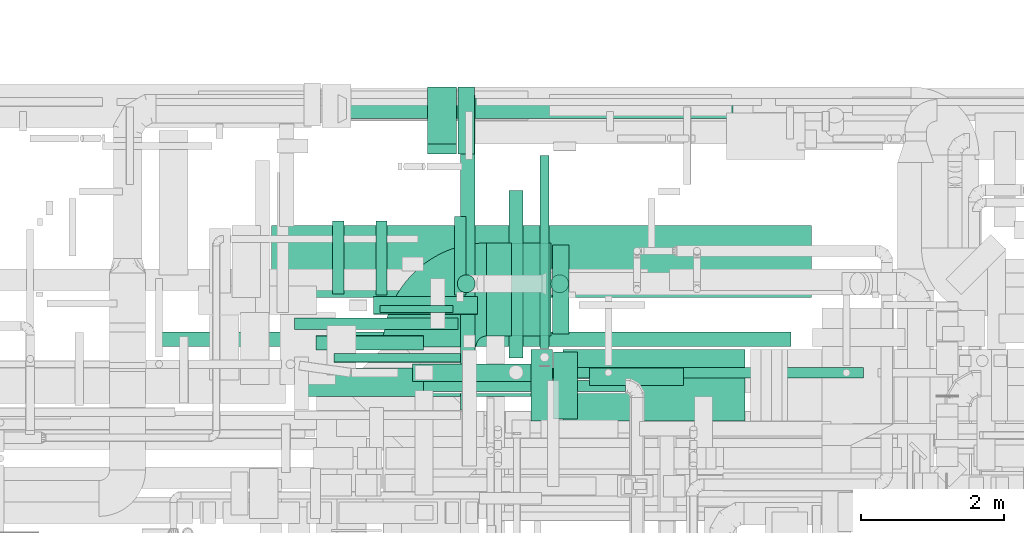
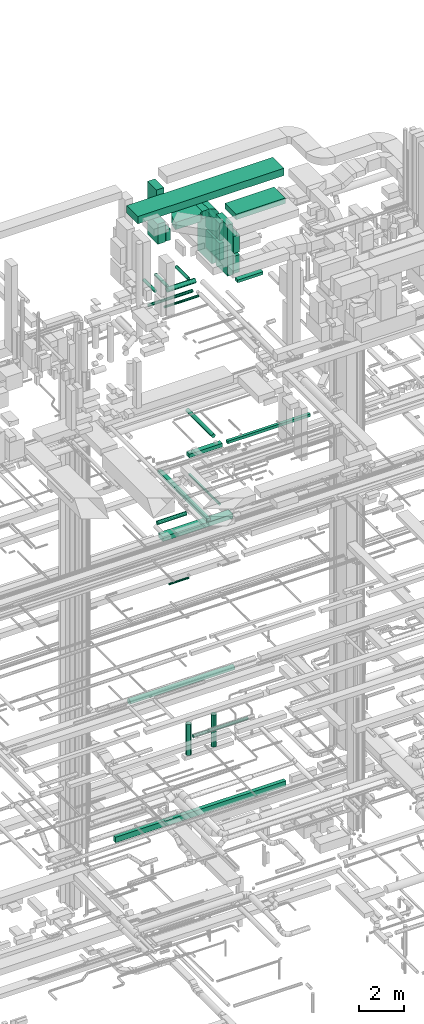
# One storey, part 72 of 337: 32 flow segments, 2 flow fittings.
"""IFC2X3 building model written with IfcOpenShell, lengths in millimetres."""

from ifc_helpers import new_model, entity, si_unit, converted_unit, derived_unit, direction, frame, frame_2d, origin, origin_2d_with_axis, place, context, subcontext, project, spatial, polyline, circle_curve, parameter, trimmed, segment, composite_curve, rectangle, circle, outline, extrude, source, transform, mapped, material, type_object, type_shapes, element, save


model = new_model("IFC2X3")

# Units and contexts
model_context = context("Model", 3, precision=0.01, world=origin(), true_north=direction((6.12303176911189e-17, 1.0)))
body_context = subcontext(model_context, "Body", "Model", "MODEL_VIEW")
ifc_project = project(units=[si_unit("LENGTHUNIT", "METRE", prefix="MILLI"), si_unit("AREAUNIT", "SQUARE_METRE"), si_unit("VOLUMEUNIT", "CUBIC_METRE"), converted_unit("PLANEANGLEUNIT", "DEGREE", entity("IfcRatioMeasure", 0.0174532925199433), si_unit("PLANEANGLEUNIT", "RADIAN"), dimensions=[0, 0, 0, 0, 0, 0, 0]), si_unit("MASSUNIT", "GRAM", prefix="KILO"), derived_unit("MASSDENSITYUNIT", [(si_unit("MASSUNIT", "GRAM", prefix="KILO"), 1), (si_unit("LENGTHUNIT", "METRE"), -3)]), derived_unit("MOMENTOFINERTIAUNIT", [(si_unit("LENGTHUNIT", "METRE"), 4)]), si_unit("TIMEUNIT", "SECOND"), si_unit("FREQUENCYUNIT", "HERTZ"), si_unit("THERMODYNAMICTEMPERATUREUNIT", "DEGREE_CELSIUS"), derived_unit("THERMALTRANSMITTANCEUNIT", [(si_unit("MASSUNIT", "GRAM", prefix="KILO"), 1), (si_unit("THERMODYNAMICTEMPERATUREUNIT", "KELVIN"), -1), (si_unit("TIMEUNIT", "SECOND"), -3)]), derived_unit("VOLUMETRICFLOWRATEUNIT", [(si_unit("LENGTHUNIT", "METRE"), 3), (si_unit("TIMEUNIT", "SECOND"), -1)]), derived_unit("MASSFLOWRATEUNIT", [(si_unit("MASSUNIT", "GRAM", prefix="KILO"), 1), (si_unit("TIMEUNIT", "SECOND"), -1)]), derived_unit("ROTATIONALFREQUENCYUNIT", [(si_unit("TIMEUNIT", "SECOND"), -1)]), si_unit("ELECTRICCURRENTUNIT", "AMPERE"), si_unit("ELECTRICVOLTAGEUNIT", "VOLT"), si_unit("POWERUNIT", "WATT"), si_unit("FORCEUNIT", "NEWTON", prefix="KILO"), si_unit("ILLUMINANCEUNIT", "LUX"), si_unit("LUMINOUSFLUXUNIT", "LUMEN"), si_unit("LUMINOUSINTENSITYUNIT", "CANDELA"), derived_unit("USERDEFINED", [(si_unit("MASSUNIT", "GRAM", prefix="KILO"), -1), (si_unit("LENGTHUNIT", "METRE"), -2), (si_unit("TIMEUNIT", "SECOND"), 3), (si_unit("LUMINOUSFLUXUNIT", "LUMEN"), 1)]), derived_unit("LINEARVELOCITYUNIT", [(si_unit("LENGTHUNIT", "METRE"), 1), (si_unit("TIMEUNIT", "SECOND"), -1)]), si_unit("PRESSUREUNIT", "PASCAL"), derived_unit("USERDEFINED", [(si_unit("LENGTHUNIT", "METRE"), -2), (si_unit("MASSUNIT", "GRAM", prefix="KILO"), 1), (si_unit("TIMEUNIT", "SECOND"), -2)]), derived_unit("LINEARFORCEUNIT", [(si_unit("MASSUNIT", "GRAM", prefix="KILO"), 1), (si_unit("LENGTHUNIT", "METRE"), 1), (si_unit("TIMEUNIT", "SECOND"), -2), (si_unit("LENGTHUNIT", "METRE"), -1)]), derived_unit("PLANARFORCEUNIT", [(si_unit("MASSUNIT", "GRAM", prefix="KILO"), 1), (si_unit("LENGTHUNIT", "METRE"), 1), (si_unit("TIMEUNIT", "SECOND"), -2), (si_unit("LENGTHUNIT", "METRE"), -2)])], contexts=[model_context])

# Site, building, storey
site_placement = place(None, origin())
site = spatial("IfcSite", under=ifc_project, at=site_placement, CompositionType="ELEMENT")
building_placement = place(site_placement, origin())
building = spatial("IfcBuilding", under=site, at=building_placement, CompositionType="ELEMENT")
storey_placement = place(building_placement, origin())
storey = spatial("IfcBuildingStorey", under=building, at=storey_placement, CompositionType="ELEMENT", Elevation=0.0)

# Flow segments
duct_segment_type_1 = type_object("IfcDuctSegmentType", PredefinedType="NOTDEFINED")
flow_segment_1_placement = place(storey_placement, frame((35783.68, 16501.37, -1325.0)))
element("IfcFlowSegment", 1, at=flow_segment_1_placement, inside=storey, type_object=duct_segment_type_1, context=body_context, shape_type="SweptSolid", body=[
    extrude(rectangle(XDim=8799.85393288675, YDim=200.0, at=origin_2d_with_axis()), frame((4399.93, 100.0, 0.0)), (0.0, 0.0, 1.0), 300.0),
])
flow_segment_2_placement = place(storey_placement, frame((41318.08, 16056.51, 18775.0)))
element("IfcFlowSegment", 2, at=flow_segment_2_placement, inside=storey, type_object=duct_segment_type_1, context=body_context, shape_type="SweptSolid", body=[
    extrude(rectangle(XDim=4279.99863965775, YDim=150.000000000001, at=origin_2d_with_axis()), frame((2140.0, 75.0, 0.0)), (0.0, 0.0, 1.0), 149.999999999999),
])
flow_segment_3_placement = place(storey_placement, frame((39298.08, 16006.51, 18750.0)))
element("IfcFlowSegment", 3, at=flow_segment_3_placement, inside=storey, type_object=duct_segment_type_1, context=body_context, shape_type="SweptSolid", body=[
    extrude(rectangle(XDim=1720.0, YDim=249.999999999999, at=origin_2d_with_axis()), frame((860.0, 125.0, 0.0), z_axis=(0.0, 0.0, 1.0), x_axis=(-1.0, 0.0, 0.0)), (0.0, 0.0, 1.0), 199.999999999998),
])
flow_segment_4_placement = place(storey_placement, frame((37828.68, 15800.0, 14825.0)))
element("IfcFlowSegment", 4, at=flow_segment_4_placement, inside=storey, type_object=duct_segment_type_1, context=body_context, shape_type="SweptSolid", body=[
    extrude(rectangle(XDim=3619.99999999995, YDim=400.0, at=origin_2d_with_axis()), frame((1810.0, 200.0, 0.0), z_axis=(0.0, 0.0, 1.0), x_axis=(-1.0, 0.0, 0.0)), (0.0, 0.0, 1.0), 249.999999999999),
])
flow_segment_5_placement = place(storey_placement, frame((39972.01, 15610.0, 15275.0)))
element("IfcFlowSegment", 5, at=flow_segment_5_placement, inside=storey, type_object=duct_segment_type_1, context=body_context, shape_type="SweptSolid", body=[
    extrude(rectangle(XDim=4399.99999999994, YDim=199.999999999998, at=origin_2d_with_axis()), frame((100.0, 2200.0, 0.0), z_axis=(0.0, 0.0, 1.0), x_axis=(0.0, 1.0, 0.0)), (0.0, 0.0, 1.0), 150.000000000001),
])
flow_segment_6_placement = place(storey_placement, frame((41771.44, 15950.55, 27475.0)))
element("IfcFlowSegment", 6, at=flow_segment_6_placement, inside=storey, type_object=duct_segment_type_1, context=body_context, shape_type="SweptSolid", body=[
    extrude(rectangle(XDim=1317.5, YDim=249.999999999999, at=origin_2d_with_axis()), frame((658.75, 125.0, 0.0), z_axis=(0.0, 0.0, 1.0), x_axis=(-1.0, 0.0, 0.0)), (0.0, 0.0, 1.0), 150.000000000001),
])
flow_segment_7_placement = place(storey_placement, frame((37330.03, 17184.6, 31500.0)))
element("IfcFlowSegment", 7, at=flow_segment_7_placement, inside=storey, type_object=duct_segment_type_1, context=body_context, shape_type="SweptSolid", body=[
    extrude(rectangle(XDim=7542.27316865098, YDim=1000.0, at=origin_2d_with_axis()), frame((3771.14, 500.0, 0.0), z_axis=(0.0, 0.0, 1.0), x_axis=(-1.0, 0.0, 0.0)), (0.0, 0.0, 1.0), 399.999999999996),
])
flow_segment_8_placement = place(storey_placement, frame((39513.7, 19323.62, 29800.0)))
element("IfcFlowSegment", 8, at=flow_segment_8_placement, inside=storey, type_object=duct_segment_type_1, context=body_context, shape_type="SweptSolid", body=[
    extrude(rectangle(XDim=399.999999999996, YDim=800.0, at=origin_2d_with_axis()), frame((200.0, 400.0, 0.0)), (0.0, 0.0, 1.0), 1480.25934788298),
])
flow_segment_9_placement = place(storey_placement, frame((39933.7, 19185.62, 28426.0)))
element("IfcFlowSegment", 9, at=flow_segment_9_placement, inside=storey, type_object=duct_segment_type_1, context=body_context, shape_type="SweptSolid", body=[
    extrude(rectangle(XDim=230.966112499476, YDim=938.000000000001, at=origin_2d_with_axis()), frame((115.48, 469.0, 0.0), z_axis=(0.0, 0.0, 1.0), x_axis=(-1.0, 0.0, 0.0)), (0.0, 0.0, 1.0), 617.999999999998),
])
flow_segment_10_placement = place(storey_placement, frame((39513.7, 19185.62, 28400.0)))
element("IfcFlowSegment", 10, at=flow_segment_10_placement, inside=storey, type_object=duct_segment_type_1, context=body_context, shape_type="SweptSolid", body=[
    extrude(rectangle(XDim=399.999999999996, YDim=937.999999999999, at=origin_2d_with_axis()), frame((200.0, 469.0, 0.0)), (0.0, 0.0, 1.0), 1100.0),
])
flow_segment_11_placement = place(storey_placement, frame((40833.7, 16644.64, 28420.0)))
element("IfcFlowSegment", 11, at=flow_segment_11_placement, inside=storey, type_object=duct_segment_type_1, context=body_context, shape_type="SweptSolid", body=[
    extrude(rectangle(XDim=400.000000000004, YDim=1300.0, at=origin_2d_with_axis()), frame((200.0, 650.0, 0.0), z_axis=(0.0, 0.0, 1.0), x_axis=(-1.0, 0.0, 0.0)), (0.0, 0.0, 1.0), 2480.0),
])
flow_segment_12_placement = place(storey_placement, frame((40337.38, 16644.64, 31050.0)))
element("IfcFlowSegment", 12, at=flow_segment_12_placement, inside=storey, type_object=duct_segment_type_1, context=body_context, shape_type="SweptSolid", body=[
    extrude(rectangle(XDim=346.314590500787, YDim=1300.0, at=origin_2d_with_axis()), frame((173.16, 650.0, 0.0), z_axis=(0.0, 0.0, 1.0), x_axis=(-1.0, 0.0, 0.0)), (0.0, 0.0, 1.0), 399.999999999996),
])
flow_segment_13_placement = place(storey_placement, frame((41253.7, 16675.64, 28426.0)))
element("IfcFlowSegment", 13, at=flow_segment_13_placement, inside=storey, type_object=duct_segment_type_1, context=body_context, shape_type="SweptSolid", body=[
    extrude(rectangle(XDim=229.999999999939, YDim=1238.0, at=origin_2d_with_axis()), frame((115.0, 619.0, 0.0), z_axis=(0.0, 0.0, 1.0), x_axis=(-1.0, 0.0, 0.0)), (0.0, 0.0, 1.0), 938.000000000003),
])
flow_segment_14_placement = place(storey_placement, frame((41253.7, 16675.64, 29516.0)))
element("IfcFlowSegment", 14, at=flow_segment_14_placement, inside=storey, type_object=duct_segment_type_1, context=body_context, shape_type="SweptSolid", body=[
    extrude(rectangle(XDim=229.99999999993, YDim=1238.0, at=origin_2d_with_axis()), frame((115.0, 619.0, 0.0), z_axis=(0.0, 0.0, 1.0), x_axis=(-1.0, 0.0, 0.0)), (0.0, 0.0, 1.0), 938.000000000003),
])
flow_segment_15_placement = place(storey_placement, frame((40953.7, 15454.64, 28420.0)))
element("IfcFlowSegment", 15, at=flow_segment_15_placement, inside=storey, type_object=duct_segment_type_1, context=body_context, shape_type="SweptSolid", body=[
    extrude(rectangle(XDim=300.000000000001, YDim=1000.0, at=origin_2d_with_axis()), frame((150.0, 500.0, 0.0), z_axis=(0.0, 0.0, 1.0), x_axis=(-1.0, 0.0, 0.0)), (0.0, 0.0, 1.0), 2780.00002500002),
])
flow_segment_16_placement = place(storey_placement, frame((41403.7, 15454.64, 31350.0)))
element("IfcFlowSegment", 16, at=flow_segment_16_placement, inside=storey, type_object=duct_segment_type_1, context=body_context, shape_type="SweptSolid", body=[
    extrude(rectangle(XDim=2541.21778793363, YDim=1000.0, at=origin_2d_with_axis()), frame((1270.61, 500.0, 0.0)), (0.0, 0.0, 1.0), 300.000000000001),
])
for number, where in (
    (17, (41273.7, 15485.64, 29516.0)),
    (18, (41273.7, 15485.64, 28426.0)),
):
    element("IfcFlowSegment", number, at=place(storey_placement, frame(where)), inside=storey, type_object=duct_segment_type_1, context=body_context, shape_type="SweptSolid", body=[
        extrude(rectangle(XDim=330.000000000029, YDim=938.000000000001, at=origin_2d_with_axis()), frame((165.0, 469.0, 0.0)), (0.0, 0.0, 1.0), 938.000000000003),
    ])
duct_segment_type_2 = type_object("IfcDuctSegmentType", PredefinedType="NOTDEFINED")
flow_segment_17_placement = place(storey_placement, frame((41081.37, 16473.29, 15235.9)))
element("IfcFlowSegment", 19, at=flow_segment_17_placement, inside=storey, type_object=duct_segment_type_2, context=body_context, shape_type="SweptSolid", body=[
    extrude(circle(Radius=62.5, at=origin_2d_with_axis()), frame((64.1, 0.0, 64.1), z_axis=(0.0, 1.0, 0.0), x_axis=(-1.0, 0.0, 0.0)), (0.0, 0.0, 1.0), 2694.99999999999),
])
flow_segment_18_placement = place(storey_placement, frame((38845.5, 16972.64, 11348.4)))
element("IfcFlowSegment", 20, at=flow_segment_18_placement, inside=storey, type_object=duct_segment_type_2, context=body_context, shape_type="SweptSolid", body=[
    extrude(circle(Radius=50.0, at=origin_2d_with_axis()), frame((0.0, 51.6, 51.6), z_axis=(1.0, 0.0, 0.0), x_axis=(0.0, 1.0, 0.0)), (0.0, 0.0, 1.0), 1020.0),
])
flow_segment_19_placement = place(storey_placement, frame((38379.85, 19677.8, 3328.4)))
element("IfcFlowSegment", 21, at=flow_segment_19_placement, inside=storey, type_object=duct_segment_type_2, context=body_context, shape_type="SweptSolid", body=[
    extrude(circle(Radius=140.0, at=origin_2d_with_axis()), frame((0.0, 141.6, 141.6), z_axis=(1.0, 0.0, 0.0), x_axis=(0.0, -1.0, 0.0)), (0.0, 0.0, 1.0), 5400.0),
])
flow_segment_20_placement = place(storey_placement, frame((39457.29, 15864.8, 3468.4)))
element("IfcFlowSegment", 22, at=flow_segment_20_placement, inside=storey, type_object=duct_segment_type_2, context=body_context, shape_type="SweptSolid", body=[
    extrude(circle(Radius=80.0, at=origin_2d_with_axis()), frame((0.0, 81.6, 81.6), z_axis=(1.0, 0.0, 0.0), x_axis=(0.0, 1.0, 0.0)), (0.0, 0.0, 1.0), 2821.87500000001),
])
flow_segment_21_placement = place(storey_placement, frame((40645.68, 16336.51, 19148.4)))
element("IfcFlowSegment", 23, at=flow_segment_21_placement, inside=storey, type_object=duct_segment_type_2, context=body_context, shape_type="SweptSolid", body=[
    extrude(circle(Radius=100.0, at=origin_2d_with_axis()), frame((101.6, 0.0, 101.6), z_axis=(0.0, 1.0, 0.0), x_axis=(1.0, 0.0, 0.0)), (0.0, 0.0, 1.0), 2341.98443809535),
])
flow_segment_22_placement = place(storey_placement, frame((37952.35, 16448.41, 15248.4)))
element("IfcFlowSegment", 24, at=flow_segment_22_placement, inside=storey, type_object=duct_segment_type_2, context=body_context, shape_type="SweptSolid", body=[
    extrude(circle(Radius=100.0, at=origin_2d_with_axis()), frame((0.0, 101.6, 101.6), z_axis=(1.0, 0.0, 0.0), x_axis=(0.0, -1.0, 0.0)), (0.0, 0.0, 1.0), 1500.00000000002),
])
flow_segment_23_placement = place(storey_placement, frame((37652.21, 16734.74, 27088.4)))
element("IfcFlowSegment", 25, at=flow_segment_23_placement, inside=storey, type_object=duct_segment_type_2, context=body_context, shape_type="SweptSolid", body=[
    extrude(circle(Radius=80.0, at=origin_2d_with_axis()), frame((0.0, 81.6, 81.6), z_axis=(1.0, 0.0, 0.0), x_axis=(0.0, 1.0, 0.0)), (0.0, 0.0, 1.0), 2282.90000000014),
])
flow_segment_24_placement = place(storey_placement, frame((38202.21, 16275.07, 27105.9)))
element("IfcFlowSegment", 26, at=flow_segment_24_placement, inside=storey, type_object=duct_segment_type_2, context=body_context, shape_type="SweptSolid", body=[
    extrude(circle(Radius=62.5, at=origin_2d_with_axis()), frame((0.0, 64.1, 64.1), z_axis=(1.0, 0.0, 0.0), x_axis=(0.0, 1.0, 0.0)), (0.0, 0.0, 1.0), 1772.90000000006),
])
flow_segment_25_placement = place(storey_placement, frame((38758.89, 16945.66, 27348.41)))
element("IfcFlowSegment", 27, at=flow_segment_25_placement, inside=storey, type_object=duct_segment_type_2, context=body_context, shape_type="SweptSolid", body=[
    extrude(circle(Radius=125.0, at=origin_2d_with_axis()), frame((0.0, 126.6, 126.6), z_axis=(1.0, 0.0, 0.0), x_axis=(0.0, 1.0, 0.0)), (0.0, 0.0, 1.0), 1451.73288561984),
])
flow_segment_26_placement = place(storey_placement, frame((38182.3, 17232.26, 27393.41)))
element("IfcFlowSegment", 28, at=flow_segment_26_placement, inside=storey, type_object=duct_segment_type_2, context=body_context, shape_type="SweptSolid", body=[
    extrude(circle(Radius=80.0, at=origin_2d_with_axis()), frame((81.6, 0.0, 81.6), z_axis=(0.0, 1.0, 0.0), x_axis=(1.0, 0.0, 0.0)), (0.0, 0.0, 1.0), 1020.0),
])
flow_segment_27_placement = place(storey_placement, frame((38786.52, 17217.26, 27473.41)))
element("IfcFlowSegment", 29, at=flow_segment_27_placement, inside=storey, type_object=duct_segment_type_2, context=body_context, shape_type="SweptSolid", body=[
    extrude(circle(Radius=80.0, at=origin_2d_with_axis()), frame((81.6, 0.0, 81.6), z_axis=(0.0, 1.0, 0.0), x_axis=(1.0, 0.0, 0.0)), (0.0, 0.0, 1.0), 1034.99999999999),
])
flow_segment_28_placement = place(storey_placement, frame((39883.59, 17217.26, 27473.41)))
element("IfcFlowSegment", 30, at=flow_segment_28_placement, inside=storey, type_object=duct_segment_type_2, context=body_context, shape_type="SweptSolid", body=[
    extrude(circle(Radius=80.0, at=origin_2d_with_axis()), frame((81.6, 0.0, 81.6), z_axis=(0.0, 1.0, 0.0), x_axis=(1.0, 0.0, 0.0)), (0.0, 0.0, 1.0), 1097.19744018355),
])
flow_segment_29_placement = place(storey_placement, frame((39925.33, 17247.68, 1500.0)))
element("IfcFlowSegment", 31, at=flow_segment_29_placement, inside=storey, type_object=duct_segment_type_2, context=body_context, shape_type="SweptSolid", body=[
    extrude(circle(Radius=125.0, at=origin_2d_with_axis()), frame((126.6, 126.6, 0.0), z_axis=(0.0, 0.0, 1.0), x_axis=(0.0, 1.0, 0.0)), (0.0, 0.0, 1.0), 1685.81906476356),
])
flow_segment_30_placement = place(storey_placement, frame((41229.73, 17247.68, 1500.0)))
element("IfcFlowSegment", 32, at=flow_segment_30_placement, inside=storey, type_object=duct_segment_type_2, context=body_context, shape_type="SweptSolid", body=[
    extrude(circle(Radius=125.0, at=origin_2d_with_axis()), frame((126.6, 126.6, 0.0), z_axis=(0.0, 0.0, 1.0), x_axis=(0.0, 1.0, 0.0)), (0.0, 0.0, 1.0), 1758.31906476356),
])

# Flow fittings
ifc_material = material()
duct_fitting_type_1 = type_object("IfcDuctFittingType", PredefinedType="NOTDEFINED", material=ifc_material)
shared_shape_1 = source(origin(), body_context, "Body", "SweptSolid", [
    extrude(outline(composite_curve([segment(polyline([(-375.0, -175.0), (25.0, -175.0)]), True, "CONTINUOUS"), segment(trimmed(circle_curve(frame_2d((175.0, -175.0), x_axis=(0.0, 1.0)), 150.0), [parameter(0.0)], [parameter(90.0000000000001)], True, "PARAMETER"), False, "CONTINUOUS"), segment(polyline([(175.0, -25.0), (175.0, 375.0)]), True, "CONTINUOUS"), segment(trimmed(circle_curve(frame_2d((175.0, -175.0), x_axis=(0.0, 1.0)), 550.0), [parameter(0.0)], [parameter(90.0)], True, "PARAMETER"), True, "CONTINUOUS")], self_intersect=False)), frame((-175.0, 175.0, -650.0), z_axis=(0.0, 0.0, 1.0), x_axis=(-1.0, 0.0, 0.0)), (0.0, 0.0, 1.0), 1300.0),
])
type_shapes(duct_fitting_type_1, [shared_shape_1])
flow_fitting_1_placement = place(storey_placement, frame((41033.7, 17294.64, 31250.0), z_axis=(0.0, 1.0, 0.0), x_axis=(1.0, 0.0, 0.0)))
element("IfcFlowFitting", 33, at=flow_fitting_1_placement, inside=storey, type_object=duct_fitting_type_1, material=ifc_material, context=body_context, shape_type="MappedRepresentation", body=[
    mapped(shared_shape_1, transform((0.0, 0.0, 0.0), scale=1.0)),
])
duct_fitting_type_2 = type_object("IfcDuctFittingType", PredefinedType="NOTDEFINED", material=ifc_material)
shared_shape_2 = source(origin(), body_context, "Body", "SweptSolid", [
    extrude(outline(composite_curve([segment(polyline([(-1050.0, -400.0), (250.0, -400.0)]), True, "CONTINUOUS"), segment(trimmed(circle_curve(frame_2d((400.0, -400.0), x_axis=(0.0, 1.0)), 149.999999999999), [parameter(0.0)], [parameter(90.0)], True, "PARAMETER"), False, "CONTINUOUS"), segment(polyline([(400.0, -250.0), (400.0, 1050.0)]), True, "CONTINUOUS"), segment(trimmed(circle_curve(frame_2d((400.0, -400.0), x_axis=(0.0, 1.0)), 1450.0), [parameter(0.0)], [parameter(90.0)], True, "PARAMETER"), True, "CONTINUOUS")], self_intersect=False)), frame((-400.0, 400.0, -200.0), z_axis=(0.0, 0.0, 1.0), x_axis=(-1.0, 0.0, 0.0)), (0.0, 0.0, 1.0), 400.0),
])
type_shapes(duct_fitting_type_2, [shared_shape_2])
flow_fitting_2_placement = place(storey_placement, frame((39537.38, 17294.64, 31250.0), z_axis=(0.0, 0.0, 1.0), x_axis=(-1.0, 0.0, 0.0)))
element("IfcFlowFitting", 34, at=flow_fitting_2_placement, inside=storey, type_object=duct_fitting_type_2, material=ifc_material, context=body_context, shape_type="MappedRepresentation", body=[
    mapped(shared_shape_2, transform((0.0, 0.0, 0.0), scale=1.0)),
])

save(model, "model.ifc")
